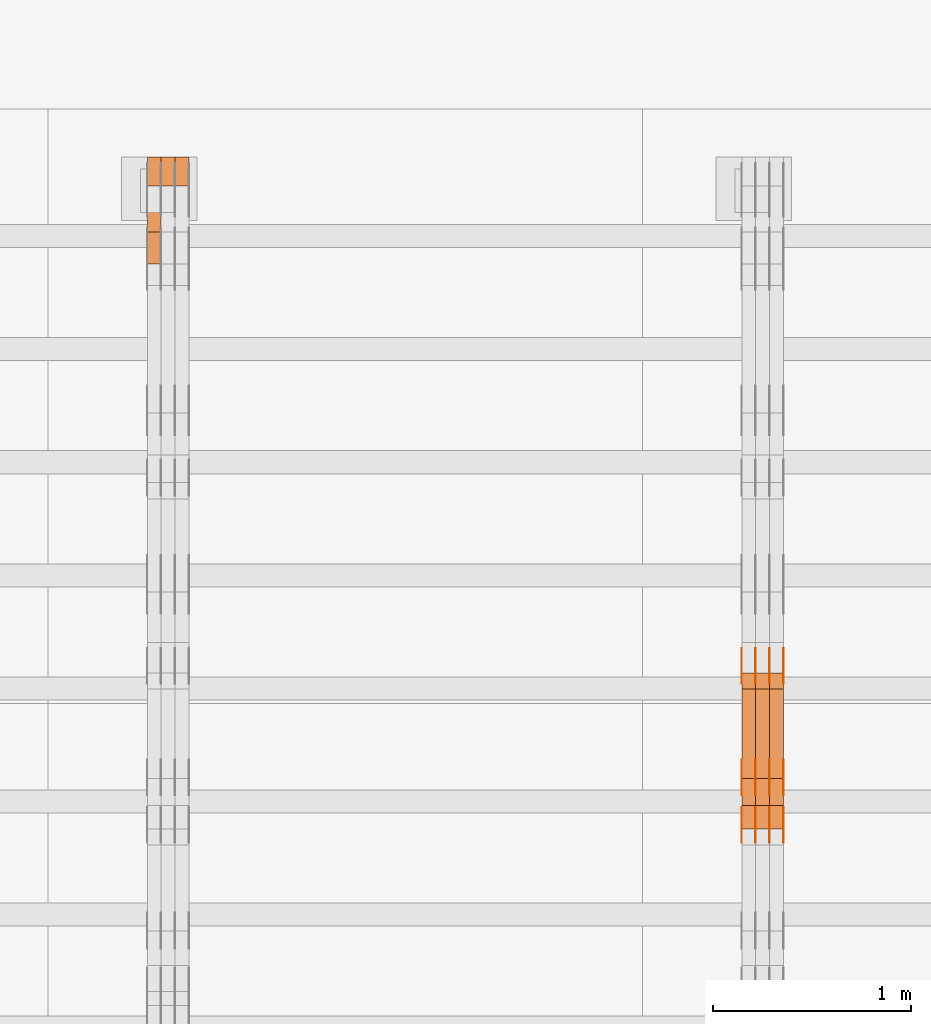
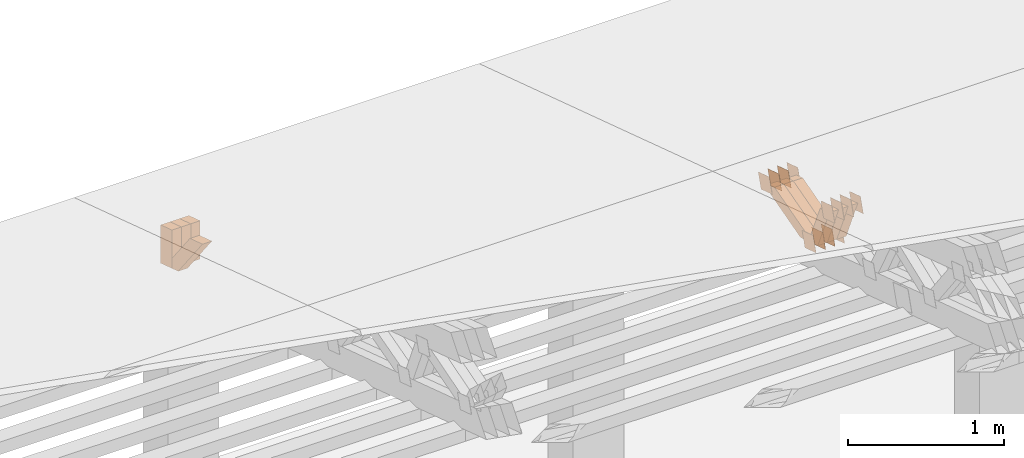
# One storey, part 361 of 385: 28 proxies.
"""IFC2X3 building model written with IfcOpenShell, lengths in millimetres."""

import ifcopenshell
import ifcopenshell.guid

model = None  # the IFC model being written
_history = None  # IfcOwnerHistory: only IFC2X3 demands one
_inside = {}  # id of a spatial element -> (the spatial element, [elements in it])
_under = {}  # id of a project, library or spatial element -> (it, [spatial elements below it])
_declared = {}  # id of a project -> (the project, [libraries it declares])
_typed = {}  # id of a type object -> (the type object, [elements of that type])
_made_of = {}  # id of a material, layer set ... -> (it, [elements and type objects made of it])


def new_model(schema):
    """Start an empty IFC model of exactly this schema.

    Asked for "IFC4X3", IfcOpenShell would pick the latest addendum, in which some entities
    have other attributes; the version numbers below select the first issue.
    IFC2X3 requires an IfcOwnerHistory on every rooted entity: one is made here for all.
    """
    global model, _history
    if schema == "IFC4X3":
        model = ifcopenshell.file(schema_version=(4, 3, 0, 0))
    else:
        model = ifcopenshell.file(schema=schema)
    _inside.clear()
    _under.clear()
    _declared.clear()
    _typed.clear()
    _made_of.clear()
    _history = None
    if model.schema == "IFC2X3":
        org = make("IfcOrganization", Name="unknown")
        user = make(
            "IfcPersonAndOrganization",
            ThePerson=make("IfcPerson", FamilyName="unknown"),
            TheOrganization=org,
        )
        app = make(
            "IfcApplication",
            ApplicationDeveloper=org,
            Version="unknown",
            ApplicationFullName="unknown",
            ApplicationIdentifier="unknown",
        )
        _history = make(
            "IfcOwnerHistory",
            OwningUser=user,
            OwningApplication=app,
            ChangeAction="ADDED",
            CreationDate=0,
        )
    return model


def make(cls, **values):
    """One entity of the class cls with the attributes given. An attribute that is None is left unset."""
    return model.create_entity(
        cls, **{name: value for name, value in values.items() if value is not None}
    )


def entity(cls, *values):
    """Any entity or typed value of the class cls, its attributes in the order of the schema. None: left unset."""
    e = model.create_entity(cls)
    for i, value in enumerate(values):
        if value is not None:
            e[i] = value
    return e


def rooted(cls, **values):
    """An entity with a GlobalId (a new one), such as an element, a storey or a relation."""
    return make(cls, GlobalId=ifcopenshell.guid.new(), OwnerHistory=_history, **values)


def si_unit(unit_type, name, prefix=None):
    """IfcSIUnit, for example si_unit("LENGTHUNIT", "METRE", prefix="MILLI")."""
    return make("IfcSIUnit", UnitType=unit_type, Prefix=prefix, Name=name)


def converted_unit(unit_type, name, factor, base, dimensions=None, offset=None):
    """IfcConversionBasedUnit, such as the inch: factor (a typed value) times the base unit."""
    return make(
        "IfcConversionBasedUnit"
        if offset is None
        else "IfcConversionBasedUnitWithOffset",
        ConversionOffset=offset,
        Dimensions=None
        if dimensions is None
        else entity("IfcDimensionalExponents", *dimensions),
        UnitType=unit_type,
        Name=name,
        ConversionFactor=make(
            "IfcMeasureWithUnit", ValueComponent=factor, UnitComponent=base
        ),
    )


def derived_unit(unit_type, elements):
    """IfcDerivedUnit: a product of units, each with its exponent."""
    return make(
        "IfcDerivedUnit",
        Elements=[
            make("IfcDerivedUnitElement", Unit=unit, Exponent=power)
            for unit, power in elements
        ],
        UnitType=unit_type,
    )


def assignment(units):
    """IfcUnitAssignment: the units of a project."""
    return None if units is None else make("IfcUnitAssignment", Units=units)


def point(xyz):
    """IfcCartesianPoint."""
    return None if xyz is None else make("IfcCartesianPoint", Coordinates=xyz)


def direction(xyz):
    """IfcDirection."""
    return None if xyz is None else make("IfcDirection", DirectionRatios=xyz)


def frame(location, z_axis=None, x_axis=None):
    """IfcAxis2Placement3D, a coordinate frame: its origin and axes. An axis left out is left unset."""
    return make(
        "IfcAxis2Placement3D",
        Location=point(location),
        Axis=direction(z_axis),
        RefDirection=direction(x_axis),
    )


def origin():
    """The frame at (0, 0, 0) with its axes left unset."""
    return frame((0.0, 0.0, 0.0))


def place(relative_to, where):
    """IfcLocalPlacement: puts the frame where relative to a parent placement (None: the world)."""
    return make(
        "IfcLocalPlacement", PlacementRelTo=relative_to, RelativePlacement=where
    )


def context(
    kind, dimensions, precision=None, world=None, true_north=None, identifier=None
):
    """IfcGeometricRepresentationContext, for example the 3D "Model" context."""
    return make(
        "IfcGeometricRepresentationContext",
        ContextIdentifier=identifier,
        ContextType=kind,
        CoordinateSpaceDimension=dimensions,
        Precision=precision,
        WorldCoordinateSystem=world,
        TrueNorth=true_north,
    )


def subcontext(parent, identifier, kind, view, scale=None):
    """IfcGeometricRepresentationSubContext, for example "Body" below "Model"."""
    return make(
        "IfcGeometricRepresentationSubContext",
        ContextIdentifier=identifier,
        ContextType=kind,
        ParentContext=parent,
        TargetScale=scale,
        TargetView=view,
    )


def project(units=None, contexts=None):
    """IfcProject with its units and contexts."""
    return rooted(
        "IfcProject",
        Name="project",
        RepresentationContexts=contexts,
        UnitsInContext=assignment(units),
    )


def spatial(cls, under=None, at=None, **own):
    """A site, building, storey or space (cls), placed at a placement, below another one or the project."""
    s = rooted(cls, ObjectPlacement=at, **own)
    if under is not None:
        _under.setdefault(under.id(), (under, []))[1].append(s)
    return s


def polyline(points):
    """IfcPolyline through the points."""
    return make("IfcPolyline", Points=[point(p) for p in points])


def outline(outer, holes=None, kind="AREA"):
    """IfcArbitraryClosedProfileDef: a profile drawn as a closed curve; with holes, ...WithVoids."""
    if holes is None:
        return make("IfcArbitraryClosedProfileDef", ProfileType=kind, OuterCurve=outer)
    return make(
        "IfcArbitraryProfileDefWithVoids",
        ProfileType=kind,
        OuterCurve=outer,
        InnerCurves=holes,
    )


def extrude(swept, where, along, depth):
    """IfcExtrudedAreaSolid: the profile swept, set in the frame where, extruded along a direction by depth."""
    return make(
        "IfcExtrudedAreaSolid",
        SweptArea=swept,
        Position=where,
        ExtrudedDirection=direction(along),
        Depth=depth,
    )


def shape(context_of_items, identifier, shape_type, items):
    """IfcShapeRepresentation: the items that make up one representation, for example the "Body"."""
    return make(
        "IfcShapeRepresentation",
        ContextOfItems=context_of_items,
        RepresentationIdentifier=identifier,
        RepresentationType=shape_type,
        Items=items,
    )


def source(mapping_origin, context_of_items, identifier, shape_type, items):
    """IfcRepresentationMap: a shape defined once, which mapped items show again and again."""
    return make(
        "IfcRepresentationMap",
        MappingOrigin=mapping_origin,
        MappedRepresentation=shape(context_of_items, identifier, shape_type, items),
    )


def transform(
    local_origin,
    x_axis=None,
    y_axis=None,
    z_axis=None,
    scale=None,
    scale2=None,
    scale3=None,
    uniform=True,
):
    """IfcCartesianTransformationOperator3D, or its non-uniform kind. x_axis, y_axis, z_axis: its Axis1, 2, 3."""
    if uniform:
        return make(
            "IfcCartesianTransformationOperator3D",
            Axis1=direction(x_axis),
            Axis2=direction(y_axis),
            LocalOrigin=point(local_origin),
            Scale=scale,
            Axis3=direction(z_axis),
        )
    return make(
        "IfcCartesianTransformationOperator3DnonUniform",
        Axis1=direction(x_axis),
        Axis2=direction(y_axis),
        LocalOrigin=point(local_origin),
        Scale=scale,
        Axis3=direction(z_axis),
        Scale2=scale2,
        Scale3=scale3,
    )


def mapped(mapping_source, mapping_target):
    """IfcMappedItem: shows the shape of a source again, moved by a transform."""
    return make(
        "IfcMappedItem", MappingSource=mapping_source, MappingTarget=mapping_target
    )


def material(Name=None, Category=None):
    """IfcMaterial."""
    return make("IfcMaterial", Name=Name, Category=Category)


def made_of(thing, what):
    """Note that an element or type object is made of a material, layer set ...; save() writes the relation."""
    if what is not None:
        _made_of.setdefault(what.id(), (what, []))[1].append(thing)
    return thing


def type_object(cls, material=None, **own):
    """A type object (cls), such as IfcWallType, which elements share."""
    return made_of(rooted(cls, **own), material)


def type_shapes(of_type, sources):
    """Give a type object the sources (RepresentationMaps) that its elements show as mapped items."""
    of_type.RepresentationMaps = sources


def element(
    cls,
    number,
    at=None,
    inside=None,
    cuts=None,
    type_object=None,
    material=None,
    context=None,
    identifier="Body",
    shape_type=None,
    held_by="IfcProductDefinitionShape",
    body=None,
    shapes=None,
    **own,
):
    """One element of the class cls, such as IfcWall. Its Tag is "e" and its number.

    at: its placement. inside: the storey or other place that contains it. cuts: it is an
    opening in that element (IfcRelVoidsElement). A single representation is given by context,
    identifier, shape_type and body (its items); several are given by shapes. held_by: the class
    of the entity that holds the representations. save() writes the other relations.
    """
    e = rooted(cls, Tag="e%d" % number, ObjectPlacement=at, **own)
    if body is not None:
        shapes = [shape(context, identifier, shape_type, body)]
    if shapes is not None:
        e.Representation = make(held_by, Representations=shapes)
    if inside is not None:
        _inside.setdefault(inside.id(), (inside, []))[1].append(e)
    if cuts is not None:
        rooted(
            "IfcRelVoidsElement", RelatingBuildingElement=cuts, RelatedOpeningElement=e
        )
    if type_object is not None:
        _typed.setdefault(type_object.id(), (type_object, []))[1].append(e)
    return made_of(e, material)


def aggregate(whole, parts):
    """IfcRelAggregates: a whole, such as a stair, and the parts it consists of."""
    return rooted("IfcRelAggregates", RelatingObject=whole, RelatedObjects=parts)


def save(model, path):
    """Write the relations noted so far, then the file.

    IfcRelAggregates (storeys below a building ...), IfcRelContainedInSpatialStructure (elements
    in a storey), IfcRelDefinesByType, IfcRelAssociatesMaterial and IfcRelDeclares: one each for
    every whole, place, type object, material and project.
    """
    for whole, parts in _under.values():
        aggregate(whole, parts)
    for where, things in _inside.values():
        rooted(
            "IfcRelContainedInSpatialStructure",
            RelatedElements=things,
            RelatingStructure=where,
        )
    for kind, things in _typed.values():
        rooted("IfcRelDefinesByType", RelatedObjects=things, RelatingType=kind)
    for what, things in _made_of.values():
        rooted("IfcRelAssociatesMaterial", RelatedObjects=things, RelatingMaterial=what)
    for by, libraries in _declared.values():
        rooted("IfcRelDeclares", RelatingContext=by, RelatedDefinitions=libraries)
    model.write(path)


model = new_model("IFC2X3")

# Units and contexts
model_context = context("Model", 3, precision=0.01, world=origin(), true_north=direction((6.12303176911189e-17, 1.0)))
body_context = subcontext(model_context, "Body", "Model", "MODEL_VIEW")
ifc_project = project(units=[si_unit("LENGTHUNIT", "METRE", prefix="MILLI"), si_unit("AREAUNIT", "SQUARE_METRE"), si_unit("VOLUMEUNIT", "CUBIC_METRE"), converted_unit("PLANEANGLEUNIT", "DEGREE", entity("IfcRatioMeasure", 0.0174532925199433), si_unit("PLANEANGLEUNIT", "RADIAN"), dimensions=[0, 0, 0, 0, 0, 0, 0]), si_unit("MASSUNIT", "GRAM", prefix="KILO"), derived_unit("MASSDENSITYUNIT", [(si_unit("MASSUNIT", "GRAM", prefix="KILO"), 1), (si_unit("LENGTHUNIT", "METRE"), -3)]), si_unit("TIMEUNIT", "SECOND"), si_unit("FREQUENCYUNIT", "HERTZ"), si_unit("THERMODYNAMICTEMPERATUREUNIT", "DEGREE_CELSIUS"), derived_unit("THERMALTRANSMITTANCEUNIT", [(si_unit("MASSUNIT", "GRAM", prefix="KILO"), 1), (si_unit("THERMODYNAMICTEMPERATUREUNIT", "KELVIN"), -1), (si_unit("TIMEUNIT", "SECOND"), -3)]), derived_unit("VOLUMETRICFLOWRATEUNIT", [(si_unit("LENGTHUNIT", "METRE"), 3), (si_unit("TIMEUNIT", "SECOND"), -1)]), si_unit("ELECTRICCURRENTUNIT", "AMPERE"), si_unit("ELECTRICVOLTAGEUNIT", "VOLT"), si_unit("POWERUNIT", "WATT"), si_unit("FORCEUNIT", "NEWTON", prefix="KILO"), si_unit("ILLUMINANCEUNIT", "LUX"), si_unit("LUMINOUSFLUXUNIT", "LUMEN"), si_unit("LUMINOUSINTENSITYUNIT", "CANDELA"), derived_unit("USERDEFINED", [(si_unit("MASSUNIT", "GRAM", prefix="KILO"), -1), (si_unit("LENGTHUNIT", "METRE"), -2), (si_unit("TIMEUNIT", "SECOND"), 3), (si_unit("LUMINOUSFLUXUNIT", "LUMEN"), 1)]), derived_unit("LINEARVELOCITYUNIT", [(si_unit("LENGTHUNIT", "METRE"), 1), (si_unit("TIMEUNIT", "SECOND"), -1)]), si_unit("PRESSUREUNIT", "PASCAL"), derived_unit("USERDEFINED", [(si_unit("LENGTHUNIT", "METRE"), -2), (si_unit("MASSUNIT", "GRAM", prefix="KILO"), 1), (si_unit("TIMEUNIT", "SECOND"), -2)])], contexts=[model_context])

# Site, building, storey
site_placement = place(None, origin())
site = spatial("IfcSite", under=ifc_project, at=site_placement, CompositionType="ELEMENT")
building_placement = place(site_placement, origin())
building = spatial("IfcBuilding", under=site, at=building_placement, CompositionType="ELEMENT")
storey_placement = place(building_placement, origin())
storey = spatial("IfcBuildingStorey", under=building, at=storey_placement, Name="Default", CompositionType="ELEMENT", Elevation=0.0)

# Proxies
ifc_material_1 = material(Name="IfcSurfaceStyle #540806")
building_element_proxy_type_1 = type_object("IfcBuildingElementProxyType", PredefinedType="NOTDEFINED", material=ifc_material_1)
shared_shape_1 = source(origin(), body_context, "Body", "SweptSolid", [
    extrude(outline(polyline([(-74.9998888504569, -59.9999264677525), (74.999884859074, -59.9999264677525), (74.9998699895559, 59.9999264677525), (-74.999865998173, 59.9999264677525), (-74.9998888504569, -59.9999264677525)])), frame((74.9999170714918, 60.0000016373507, 0.0), z_axis=(0.0, 0.0, 1.0), x_axis=(-1.0, 0.0, 0.0)), (0.0, 0.0, 1.0), 1.3),
])
type_shapes(building_element_proxy_type_1, [shared_shape_1])
proxy_1_placement = place(building_placement, frame((45386.3, 23182.5962361838, 1409.76695322432), z_axis=(-1.0, 0.0, 0.0), x_axis=(0.0, -0.951056516295154, 0.309016994374948)))
element("IfcBuildingElementProxy", 1, at=proxy_1_placement, inside=storey, type_object=building_element_proxy_type_1, material=ifc_material_1, context=body_context, shape_type="MappedRepresentation", body=[
    mapped(shared_shape_1, transform((0.0, 0.0, 0.0), scale=1.0)),
])
ifc_material_2 = material(Name="IfcSurfaceStyle #540749")
building_element_proxy_type_2 = type_object("IfcBuildingElementProxyType", PredefinedType="NOTDEFINED", material=ifc_material_2)
shared_shape_2 = source(origin(), body_context, "Body", "SweptSolid", [
    extrude(outline(polyline([(-74.9998888504569, -59.9999264677525), (74.999884859074, -59.9999264677525), (74.9998699895559, 59.9999264677525), (-74.999865998173, 59.9999264677525), (-74.9998888504569, -59.9999264677525)])), frame((74.9999170714918, 60.0000016373507, 0.0), z_axis=(0.0, 0.0, 1.0), x_axis=(-1.0, 0.0, 0.0)), (0.0, 0.0, 1.0), 1.3),
])
type_shapes(building_element_proxy_type_2, [shared_shape_2])
proxy_2_placement = place(building_placement, frame((45315.0, 23182.5962361838, 1409.76695322432), z_axis=(-1.0, 0.0, 0.0), x_axis=(0.0, -0.951056516295154, 0.309016994374948)))
element("IfcBuildingElementProxy", 2, at=proxy_2_placement, inside=storey, type_object=building_element_proxy_type_2, material=ifc_material_2, context=body_context, shape_type="MappedRepresentation", body=[
    mapped(shared_shape_2, transform((0.0, 0.0, 0.0), scale=1.0)),
])
ifc_material_3 = material(Name="IfcSurfaceStyle #540692")
building_element_proxy_type_3 = type_object("IfcBuildingElementProxyType", PredefinedType="NOTDEFINED", material=ifc_material_3)
shared_shape_3 = source(origin(), body_context, "Body", "SweptSolid", [
    extrude(outline(polyline([(-74.9998888504569, -59.9999264677525), (74.999884859074, -59.9999264677525), (74.9998699895559, 59.9999264677525), (-74.999865998173, 59.9999264677525), (-74.9998888504569, -59.9999264677525)])), frame((74.9999170714918, 60.0000016373507, 0.0), z_axis=(0.0, 0.0, 1.0), x_axis=(-1.0, 0.0, 0.0)), (0.0, 0.0, 1.0), 1.3),
])
type_shapes(building_element_proxy_type_3, [shared_shape_3])
proxy_3_placement = place(building_placement, frame((45316.3, 23182.5962361838, 1409.76695322432), z_axis=(-1.0, 0.0, 0.0), x_axis=(0.0, -0.951056516295154, 0.309016994374948)))
element("IfcBuildingElementProxy", 3, at=proxy_3_placement, inside=storey, type_object=building_element_proxy_type_3, material=ifc_material_3, context=body_context, shape_type="MappedRepresentation", body=[
    mapped(shared_shape_3, transform((0.0, 0.0, 0.0), scale=1.0)),
])
ifc_material_4 = material(Name="IfcSurfaceStyle #540635")
building_element_proxy_type_4 = type_object("IfcBuildingElementProxyType", PredefinedType="NOTDEFINED", material=ifc_material_4)
shared_shape_4 = source(origin(), body_context, "Body", "SweptSolid", [
    extrude(outline(polyline([(-74.9998888504569, -59.9999264677525), (74.999884859074, -59.9999264677525), (74.9998699895559, 59.9999264677525), (-74.999865998173, 59.9999264677525), (-74.9998888504569, -59.9999264677525)])), frame((74.9999170714918, 60.0000016373507, 0.0), z_axis=(0.0, 0.0, 1.0), x_axis=(-1.0, 0.0, 0.0)), (0.0, 0.0, 1.0), 1.29999999999999),
])
type_shapes(building_element_proxy_type_4, [shared_shape_4])
proxy_4_placement = place(building_placement, frame((45245.0, 23182.5962361838, 1409.76695322432), z_axis=(-1.0, 0.0, 0.0), x_axis=(0.0, -0.951056516295154, 0.309016994374948)))
element("IfcBuildingElementProxy", 4, at=proxy_4_placement, inside=storey, type_object=building_element_proxy_type_4, material=ifc_material_4, context=body_context, shape_type="MappedRepresentation", body=[
    mapped(shared_shape_4, transform((0.0, 0.0, 0.0), scale=1.0)),
])
ifc_material_5 = material(Name="IfcSurfaceStyle #540578")
building_element_proxy_type_5 = type_object("IfcBuildingElementProxyType", PredefinedType="NOTDEFINED", material=ifc_material_5)
shared_shape_5 = source(origin(), body_context, "Body", "SweptSolid", [
    extrude(outline(polyline([(-74.9998888504569, -59.9999264677525), (74.999884859074, -59.9999264677525), (74.9998699895559, 59.9999264677525), (-74.999865998173, 59.9999264677525), (-74.9998888504569, -59.9999264677525)])), frame((74.9999170714918, 60.0000016373507, 0.0), z_axis=(0.0, 0.0, 1.0), x_axis=(-1.0, 0.0, 0.0)), (0.0, 0.0, 1.0), 1.29999999999999),
])
type_shapes(building_element_proxy_type_5, [shared_shape_5])
proxy_5_placement = place(building_placement, frame((45246.3, 23182.5962361838, 1409.76695322432), z_axis=(-1.0, 0.0, 0.0), x_axis=(0.0, -0.951056516295154, 0.309016994374948)))
element("IfcBuildingElementProxy", 5, at=proxy_5_placement, inside=storey, type_object=building_element_proxy_type_5, material=ifc_material_5, context=body_context, shape_type="MappedRepresentation", body=[
    mapped(shared_shape_5, transform((0.0, 0.0, 0.0), scale=1.0)),
])
ifc_material_6 = material(Name="IfcSurfaceStyle #540521")
building_element_proxy_type_6 = type_object("IfcBuildingElementProxyType", PredefinedType="NOTDEFINED", material=ifc_material_6)
shared_shape_6 = source(origin(), body_context, "Body", "SweptSolid", [
    extrude(outline(polyline([(-74.9998888504569, -59.9999264677525), (74.999884859074, -59.9999264677525), (74.9998699895559, 59.9999264677525), (-74.999865998173, 59.9999264677525), (-74.9998888504569, -59.9999264677525)])), frame((74.9999170714918, 60.0000016373507, 0.0), z_axis=(0.0, 0.0, 1.0), x_axis=(-1.0, 0.0, 0.0)), (0.0, 0.0, 1.0), 1.29999999999999),
])
type_shapes(building_element_proxy_type_6, [shared_shape_6])
proxy_6_placement = place(building_placement, frame((45175.0, 23182.5962361838, 1409.76695322432), z_axis=(-1.0, 0.0, 0.0), x_axis=(0.0, -0.951056516295154, 0.309016994374948)))
element("IfcBuildingElementProxy", 6, at=proxy_6_placement, inside=storey, type_object=building_element_proxy_type_6, material=ifc_material_6, context=body_context, shape_type="MappedRepresentation", body=[
    mapped(shared_shape_6, transform((0.0, 0.0, 0.0), scale=1.0)),
])
ifc_material_7 = material(Name="IfcSurfaceStyle #540464")
building_element_proxy_type_7 = type_object("IfcBuildingElementProxyType", PredefinedType="NOTDEFINED", material=ifc_material_7)
shared_shape_7 = source(origin(), body_context, "Body", "SweptSolid", [
    extrude(outline(polyline([(-75.000111611545, -60.0000599592451), (75.0000887592491, -60.0000599592451), (75.000111611545, 60.0000599592451), (-75.0000887592492, 60.0000599592451), (-75.000111611545, -60.0000599592451)])), frame((75.000111611545, 60.0000599592451, 0.0), z_axis=(0.0, 0.0, 1.0), x_axis=(-1.0, 0.0, 0.0)), (0.0, 0.0, 1.0), 1.3),
])
type_shapes(building_element_proxy_type_7, [shared_shape_7])
proxy_7_placement = place(building_placement, frame((45386.3, 23422.738257852, 1031.33757447264), z_axis=(-1.0, 0.0, 0.0), x_axis=(0.0, -0.951056516295124, 0.309016994375039)))
element("IfcBuildingElementProxy", 7, at=proxy_7_placement, inside=storey, type_object=building_element_proxy_type_7, material=ifc_material_7, context=body_context, shape_type="MappedRepresentation", body=[
    mapped(shared_shape_7, transform((0.0, 0.0, 0.0), scale=1.0)),
])
ifc_material_8 = material(Name="IfcSurfaceStyle #540407")
building_element_proxy_type_8 = type_object("IfcBuildingElementProxyType", PredefinedType="NOTDEFINED", material=ifc_material_8)
shared_shape_8 = source(origin(), body_context, "Body", "SweptSolid", [
    extrude(outline(polyline([(-75.000111611545, -60.0000599592451), (75.0000887592491, -60.0000599592451), (75.000111611545, 60.0000599592451), (-75.0000887592492, 60.0000599592451), (-75.000111611545, -60.0000599592451)])), frame((75.000111611545, 60.0000599592451, 0.0), z_axis=(0.0, 0.0, 1.0), x_axis=(-1.0, 0.0, 0.0)), (0.0, 0.0, 1.0), 1.3),
])
type_shapes(building_element_proxy_type_8, [shared_shape_8])
proxy_8_placement = place(building_placement, frame((45315.0, 23422.738257852, 1031.33757447264), z_axis=(-1.0, 0.0, 0.0), x_axis=(0.0, -0.951056516295124, 0.309016994375039)))
element("IfcBuildingElementProxy", 8, at=proxy_8_placement, inside=storey, type_object=building_element_proxy_type_8, material=ifc_material_8, context=body_context, shape_type="MappedRepresentation", body=[
    mapped(shared_shape_8, transform((0.0, 0.0, 0.0), scale=1.0)),
])
ifc_material_9 = material(Name="IfcSurfaceStyle #540350")
building_element_proxy_type_9 = type_object("IfcBuildingElementProxyType", PredefinedType="NOTDEFINED", material=ifc_material_9)
shared_shape_9 = source(origin(), body_context, "Body", "SweptSolid", [
    extrude(outline(polyline([(-75.000111611545, -60.0000599592451), (75.0000887592491, -60.0000599592451), (75.000111611545, 60.0000599592451), (-75.0000887592492, 60.0000599592451), (-75.000111611545, -60.0000599592451)])), frame((75.000111611545, 60.0000599592451, 0.0), z_axis=(0.0, 0.0, 1.0), x_axis=(-1.0, 0.0, 0.0)), (0.0, 0.0, 1.0), 1.3),
])
type_shapes(building_element_proxy_type_9, [shared_shape_9])
proxy_9_placement = place(building_placement, frame((45316.3, 23422.738257852, 1031.33757447264), z_axis=(-1.0, 0.0, 0.0), x_axis=(0.0, -0.951056516295124, 0.309016994375039)))
element("IfcBuildingElementProxy", 9, at=proxy_9_placement, inside=storey, type_object=building_element_proxy_type_9, material=ifc_material_9, context=body_context, shape_type="MappedRepresentation", body=[
    mapped(shared_shape_9, transform((0.0, 0.0, 0.0), scale=1.0)),
])
ifc_material_10 = material(Name="IfcSurfaceStyle #540293")
building_element_proxy_type_10 = type_object("IfcBuildingElementProxyType", PredefinedType="NOTDEFINED", material=ifc_material_10)
shared_shape_10 = source(origin(), body_context, "Body", "SweptSolid", [
    extrude(outline(polyline([(-75.000111611545, -60.0000599592451), (75.0000887592491, -60.0000599592451), (75.000111611545, 60.0000599592451), (-75.0000887592492, 60.0000599592451), (-75.000111611545, -60.0000599592451)])), frame((75.000111611545, 60.0000599592451, 0.0), z_axis=(0.0, 0.0, 1.0), x_axis=(-1.0, 0.0, 0.0)), (0.0, 0.0, 1.0), 1.29999999999999),
])
type_shapes(building_element_proxy_type_10, [shared_shape_10])
proxy_10_placement = place(building_placement, frame((45245.0, 23422.738257852, 1031.33757447264), z_axis=(-1.0, 0.0, 0.0), x_axis=(0.0, -0.951056516295124, 0.309016994375039)))
element("IfcBuildingElementProxy", 10, at=proxy_10_placement, inside=storey, type_object=building_element_proxy_type_10, material=ifc_material_10, context=body_context, shape_type="MappedRepresentation", body=[
    mapped(shared_shape_10, transform((0.0, 0.0, 0.0), scale=1.0)),
])
ifc_material_11 = material(Name="IfcSurfaceStyle #540236")
building_element_proxy_type_11 = type_object("IfcBuildingElementProxyType", PredefinedType="NOTDEFINED", material=ifc_material_11)
shared_shape_11 = source(origin(), body_context, "Body", "SweptSolid", [
    extrude(outline(polyline([(-75.000111611545, -60.0000599592451), (75.0000887592491, -60.0000599592451), (75.000111611545, 60.0000599592451), (-75.0000887592492, 60.0000599592451), (-75.000111611545, -60.0000599592451)])), frame((75.000111611545, 60.0000599592451, 0.0), z_axis=(0.0, 0.0, 1.0), x_axis=(-1.0, 0.0, 0.0)), (0.0, 0.0, 1.0), 1.29999999999999),
])
type_shapes(building_element_proxy_type_11, [shared_shape_11])
proxy_11_placement = place(building_placement, frame((45246.3, 23422.738257852, 1031.33757447264), z_axis=(-1.0, 0.0, 0.0), x_axis=(0.0, -0.951056516295124, 0.309016994375039)))
element("IfcBuildingElementProxy", 11, at=proxy_11_placement, inside=storey, type_object=building_element_proxy_type_11, material=ifc_material_11, context=body_context, shape_type="MappedRepresentation", body=[
    mapped(shared_shape_11, transform((0.0, 0.0, 0.0), scale=1.0)),
])
ifc_material_12 = material(Name="IfcSurfaceStyle #540179")
building_element_proxy_type_12 = type_object("IfcBuildingElementProxyType", PredefinedType="NOTDEFINED", material=ifc_material_12)
shared_shape_12 = source(origin(), body_context, "Body", "SweptSolid", [
    extrude(outline(polyline([(-75.000111611545, -60.0000599592451), (75.0000887592491, -60.0000599592451), (75.000111611545, 60.0000599592451), (-75.0000887592492, 60.0000599592451), (-75.000111611545, -60.0000599592451)])), frame((75.000111611545, 60.0000599592451, 0.0), z_axis=(0.0, 0.0, 1.0), x_axis=(-1.0, 0.0, 0.0)), (0.0, 0.0, 1.0), 1.29999999999999),
])
type_shapes(building_element_proxy_type_12, [shared_shape_12])
proxy_12_placement = place(building_placement, frame((45175.0, 23422.738257852, 1031.33757447264), z_axis=(-1.0, 0.0, 0.0), x_axis=(0.0, -0.951056516295124, 0.309016994375039)))
element("IfcBuildingElementProxy", 12, at=proxy_12_placement, inside=storey, type_object=building_element_proxy_type_12, material=ifc_material_12, context=body_context, shape_type="MappedRepresentation", body=[
    mapped(shared_shape_12, transform((0.0, 0.0, 0.0), scale=1.0)),
])
ifc_material_13 = material(Name="IfcSurfaceStyle #539780")
building_element_proxy_type_13 = type_object("IfcBuildingElementProxyType", PredefinedType="NOTDEFINED", material=ifc_material_13)
shared_shape_13 = source(origin(), body_context, "Body", "SweptSolid", [
    extrude(outline(polyline([(-74.9999766548731, -60.0000019113547), (75.000223715922, -60.0000019113547), (74.9997444633404, 60.0000019113548), (-74.9999915243893, 60.0000019113547), (-74.9999766548731, -60.0000019113547)])), frame((75.0002237159219, 60.0000770809529, 0.0), z_axis=(0.0, 0.0, 1.0), x_axis=(-1.0, 0.0, 0.0)), (0.0, 0.0, 1.0), 1.3),
])
type_shapes(building_element_proxy_type_13, [shared_shape_13])
proxy_13_placement = place(building_placement, frame((45386.3, 23985.88473314, 1148.76266928562), z_axis=(-1.0, 0.0, 0.0), x_axis=(0.0, -0.951056516295154, 0.309016994374948)))
element("IfcBuildingElementProxy", 13, at=proxy_13_placement, inside=storey, type_object=building_element_proxy_type_13, material=ifc_material_13, context=body_context, shape_type="MappedRepresentation", body=[
    mapped(shared_shape_13, transform((0.0, 0.0, 0.0), scale=1.0)),
])
ifc_material_14 = material(Name="IfcSurfaceStyle #539723")
building_element_proxy_type_14 = type_object("IfcBuildingElementProxyType", PredefinedType="NOTDEFINED", material=ifc_material_14)
shared_shape_14 = source(origin(), body_context, "Body", "SweptSolid", [
    extrude(outline(polyline([(-74.9999766548731, -60.0000019113547), (75.000223715922, -60.0000019113547), (74.9997444633404, 60.0000019113548), (-74.9999915243893, 60.0000019113547), (-74.9999766548731, -60.0000019113547)])), frame((75.0002237159219, 60.0000770809529, 0.0), z_axis=(0.0, 0.0, 1.0), x_axis=(-1.0, 0.0, 0.0)), (0.0, 0.0, 1.0), 1.3),
])
type_shapes(building_element_proxy_type_14, [shared_shape_14])
proxy_14_placement = place(building_placement, frame((45315.0, 23985.88473314, 1148.76266928562), z_axis=(-1.0, 0.0, 0.0), x_axis=(0.0, -0.951056516295154, 0.309016994374948)))
element("IfcBuildingElementProxy", 14, at=proxy_14_placement, inside=storey, type_object=building_element_proxy_type_14, material=ifc_material_14, context=body_context, shape_type="MappedRepresentation", body=[
    mapped(shared_shape_14, transform((0.0, 0.0, 0.0), scale=1.0)),
])
ifc_material_15 = material(Name="IfcSurfaceStyle #539666")
building_element_proxy_type_15 = type_object("IfcBuildingElementProxyType", PredefinedType="NOTDEFINED", material=ifc_material_15)
shared_shape_15 = source(origin(), body_context, "Body", "SweptSolid", [
    extrude(outline(polyline([(-74.9999766548731, -60.0000019113547), (75.000223715922, -60.0000019113547), (74.9997444633404, 60.0000019113548), (-74.9999915243893, 60.0000019113547), (-74.9999766548731, -60.0000019113547)])), frame((75.0002237159219, 60.0000770809529, 0.0), z_axis=(0.0, 0.0, 1.0), x_axis=(-1.0, 0.0, 0.0)), (0.0, 0.0, 1.0), 1.3),
])
type_shapes(building_element_proxy_type_15, [shared_shape_15])
proxy_15_placement = place(building_placement, frame((45316.3, 23985.88473314, 1148.76266928562), z_axis=(-1.0, 0.0, 0.0), x_axis=(0.0, -0.951056516295154, 0.309016994374948)))
element("IfcBuildingElementProxy", 15, at=proxy_15_placement, inside=storey, type_object=building_element_proxy_type_15, material=ifc_material_15, context=body_context, shape_type="MappedRepresentation", body=[
    mapped(shared_shape_15, transform((0.0, 0.0, 0.0), scale=1.0)),
])
ifc_material_16 = material(Name="IfcSurfaceStyle #539609")
building_element_proxy_type_16 = type_object("IfcBuildingElementProxyType", PredefinedType="NOTDEFINED", material=ifc_material_16)
shared_shape_16 = source(origin(), body_context, "Body", "SweptSolid", [
    extrude(outline(polyline([(-74.9999766548731, -60.0000019113547), (75.000223715922, -60.0000019113547), (74.9997444633404, 60.0000019113548), (-74.9999915243893, 60.0000019113547), (-74.9999766548731, -60.0000019113547)])), frame((75.0002237159219, 60.0000770809529, 0.0), z_axis=(0.0, 0.0, 1.0), x_axis=(-1.0, 0.0, 0.0)), (0.0, 0.0, 1.0), 1.29999999999999),
])
type_shapes(building_element_proxy_type_16, [shared_shape_16])
proxy_16_placement = place(building_placement, frame((45245.0, 23985.88473314, 1148.76266928562), z_axis=(-1.0, 0.0, 0.0), x_axis=(0.0, -0.951056516295154, 0.309016994374948)))
element("IfcBuildingElementProxy", 16, at=proxy_16_placement, inside=storey, type_object=building_element_proxy_type_16, material=ifc_material_16, context=body_context, shape_type="MappedRepresentation", body=[
    mapped(shared_shape_16, transform((0.0, 0.0, 0.0), scale=1.0)),
])
ifc_material_17 = material(Name="IfcSurfaceStyle #539552")
building_element_proxy_type_17 = type_object("IfcBuildingElementProxyType", PredefinedType="NOTDEFINED", material=ifc_material_17)
shared_shape_17 = source(origin(), body_context, "Body", "SweptSolid", [
    extrude(outline(polyline([(-74.9999766548731, -60.0000019113547), (75.000223715922, -60.0000019113547), (74.9997444633404, 60.0000019113548), (-74.9999915243893, 60.0000019113547), (-74.9999766548731, -60.0000019113547)])), frame((75.0002237159219, 60.0000770809529, 0.0), z_axis=(0.0, 0.0, 1.0), x_axis=(-1.0, 0.0, 0.0)), (0.0, 0.0, 1.0), 1.29999999999999),
])
type_shapes(building_element_proxy_type_17, [shared_shape_17])
proxy_17_placement = place(building_placement, frame((45246.3, 23985.88473314, 1148.76266928562), z_axis=(-1.0, 0.0, 0.0), x_axis=(0.0, -0.951056516295154, 0.309016994374948)))
element("IfcBuildingElementProxy", 17, at=proxy_17_placement, inside=storey, type_object=building_element_proxy_type_17, material=ifc_material_17, context=body_context, shape_type="MappedRepresentation", body=[
    mapped(shared_shape_17, transform((0.0, 0.0, 0.0), scale=1.0)),
])
ifc_material_18 = material(Name="IfcSurfaceStyle #539495")
building_element_proxy_type_18 = type_object("IfcBuildingElementProxyType", PredefinedType="NOTDEFINED", material=ifc_material_18)
shared_shape_18 = source(origin(), body_context, "Body", "SweptSolid", [
    extrude(outline(polyline([(-74.9999766548731, -60.0000019113547), (75.000223715922, -60.0000019113547), (74.9997444633404, 60.0000019113548), (-74.9999915243893, 60.0000019113547), (-74.9999766548731, -60.0000019113547)])), frame((75.0002237159219, 60.0000770809529, 0.0), z_axis=(0.0, 0.0, 1.0), x_axis=(-1.0, 0.0, 0.0)), (0.0, 0.0, 1.0), 1.29999999999999),
])
type_shapes(building_element_proxy_type_18, [shared_shape_18])
proxy_18_placement = place(building_placement, frame((45175.0, 23985.88473314, 1148.76266928562), z_axis=(-1.0, 0.0, 0.0), x_axis=(0.0, -0.951056516295154, 0.309016994374948)))
element("IfcBuildingElementProxy", 18, at=proxy_18_placement, inside=storey, type_object=building_element_proxy_type_18, material=ifc_material_18, context=body_context, shape_type="MappedRepresentation", body=[
    mapped(shared_shape_18, transform((0.0, 0.0, 0.0), scale=1.0)),
])
ifc_material_19 = material(Name="IfcSurfaceStyle #527954")
building_element_proxy_type_19 = type_object("IfcBuildingElementProxyType", Name="T1-W48 527952", PredefinedType="NOTDEFINED", material=ifc_material_19)
shared_shape_19 = source(origin(), body_context, "Body", "SweptSolid", [
    extrude(outline(polyline([(-179.014659681673, -47.5001725722734), (164.970934255612, -47.5001725722734), (158.689466064455, -0.000154807462590734), (117.249257288395, 47.5002499760047), (-261.894997926789, 47.5002499760047), (-179.014659681673, -47.5001725722734)])), frame((164.970934255612, 47.5002499760047, 0.0), z_axis=(0.0, 0.0, 1.0), x_axis=(-1.0, 0.0, 0.0)), (0.0, 0.0, 1.0), 70.0),
])
type_shapes(building_element_proxy_type_19, [shared_shape_19])
proxy_19_placement = place(building_placement, frame((45385.0, 23276.999081075, 1103.96808602322), z_axis=(-1.0, 0.0, 0.0), x_axis=(0.0, -0.392372359952232, 0.919806463961586)))
element("IfcBuildingElementProxy", 19, at=proxy_19_placement, inside=storey, type_object=building_element_proxy_type_19, material=ifc_material_19, Name="T1-W48", context=body_context, shape_type="MappedRepresentation", body=[
    mapped(shared_shape_19, transform((0.0, 0.0, 0.0), scale=1.0)),
])
ifc_material_20 = material(Name="IfcSurfaceStyle #527888")
building_element_proxy_type_20 = type_object("IfcBuildingElementProxyType", Name="T1-W48 527886", PredefinedType="NOTDEFINED", material=ifc_material_20)
shared_shape_20 = source(origin(), body_context, "Body", "SweptSolid", [
    extrude(outline(polyline([(-179.014659681673, -47.5001725722734), (164.970934255612, -47.5001725722734), (158.689466064455, -0.000154807462590734), (117.249257288395, 47.5002499760047), (-261.894997926789, 47.5002499760047), (-179.014659681673, -47.5001725722734)])), frame((164.970934255612, 47.5002499760047, 0.0), z_axis=(0.0, 0.0, 1.0), x_axis=(-1.0, 0.0, 0.0)), (0.0, 0.0, 1.0), 70.0),
])
type_shapes(building_element_proxy_type_20, [shared_shape_20])
proxy_20_placement = place(building_placement, frame((45315.0, 23276.999081075, 1103.96808602322), z_axis=(-1.0, 0.0, 0.0), x_axis=(0.0, -0.392372359952232, 0.919806463961586)))
element("IfcBuildingElementProxy", 20, at=proxy_20_placement, inside=storey, type_object=building_element_proxy_type_20, material=ifc_material_20, Name="T1-W48", context=body_context, shape_type="MappedRepresentation", body=[
    mapped(shared_shape_20, transform((0.0, 0.0, 0.0), scale=1.0)),
])
ifc_material_21 = material(Name="IfcSurfaceStyle #527822")
building_element_proxy_type_21 = type_object("IfcBuildingElementProxyType", Name="T1-W48 527820", PredefinedType="NOTDEFINED", material=ifc_material_21)
shared_shape_21 = source(origin(), body_context, "Body", "SweptSolid", [
    extrude(outline(polyline([(-179.014659681673, -47.5001725722734), (164.970934255612, -47.5001725722734), (158.689466064455, -0.000154807462590734), (117.249257288395, 47.5002499760047), (-261.894997926789, 47.5002499760047), (-179.014659681673, -47.5001725722734)])), frame((164.970934255612, 47.5002499760047, 0.0), z_axis=(0.0, 0.0, 1.0), x_axis=(-1.0, 0.0, 0.0)), (0.0, 0.0, 1.0), 70.0),
])
type_shapes(building_element_proxy_type_21, [shared_shape_21])
proxy_21_placement = place(building_placement, frame((45245.0, 23276.999081075, 1103.96808602322), z_axis=(-1.0, 0.0, 0.0), x_axis=(0.0, -0.392372359952232, 0.919806463961586)))
element("IfcBuildingElementProxy", 21, at=proxy_21_placement, inside=storey, type_object=building_element_proxy_type_21, material=ifc_material_21, Name="T1-W48", context=body_context, shape_type="MappedRepresentation", body=[
    mapped(shared_shape_21, transform((0.0, 0.0, 0.0), scale=1.0)),
])
ifc_material_22 = material(Name="IfcSurfaceStyle #527558")
building_element_proxy_type_22 = type_object("IfcBuildingElementProxyType", Name="T1-W16 527556", PredefinedType="NOTDEFINED", material=ifc_material_22)
shared_shape_22 = source(origin(), body_context, "Body", "SweptSolid", [
    extrude(outline(polyline([(-370.757125176074, -47.4999438400901), (145.934648032773, -47.4999438400902), (217.511780472151, -4.11857860007858e-05), (234.91308660316, 47.4999644329832), (-227.602389932009, 47.4999644329832), (-370.757125176074, -47.4999438400901)])), frame((234.913162148205, 47.5000075544853, 0.0), z_axis=(0.0, 0.0, 1.0), x_axis=(-1.0, 0.0, 0.0)), (0.0, 0.0, 1.0), 70.0),
])
type_shapes(building_element_proxy_type_22, [shared_shape_22])
proxy_22_placement = place(building_placement, frame((45385.0, 23927.1704945031, 1199.43003244777), z_axis=(-1.0, 0.0, 0.0), x_axis=(0.0, -0.963308155550006, -0.268397834288666)))
element("IfcBuildingElementProxy", 22, at=proxy_22_placement, inside=storey, type_object=building_element_proxy_type_22, material=ifc_material_22, Name="T1-W16", context=body_context, shape_type="MappedRepresentation", body=[
    mapped(shared_shape_22, transform((0.0, 0.0, 0.0), scale=1.0)),
])
ifc_material_23 = material(Name="IfcSurfaceStyle #527492")
building_element_proxy_type_23 = type_object("IfcBuildingElementProxyType", Name="T1-W16 527490", PredefinedType="NOTDEFINED", material=ifc_material_23)
shared_shape_23 = source(origin(), body_context, "Body", "SweptSolid", [
    extrude(outline(polyline([(-370.757125176074, -47.4999438400901), (145.934648032773, -47.4999438400902), (217.511780472151, -4.11857860007858e-05), (234.91308660316, 47.4999644329832), (-227.602389932009, 47.4999644329832), (-370.757125176074, -47.4999438400901)])), frame((234.913162148205, 47.5000075544853, 0.0), z_axis=(0.0, 0.0, 1.0), x_axis=(-1.0, 0.0, 0.0)), (0.0, 0.0, 1.0), 70.0),
])
type_shapes(building_element_proxy_type_23, [shared_shape_23])
proxy_23_placement = place(building_placement, frame((45315.0, 23927.1704945031, 1199.43003244777), z_axis=(-1.0, 0.0, 0.0), x_axis=(0.0, -0.963308155550006, -0.268397834288666)))
element("IfcBuildingElementProxy", 23, at=proxy_23_placement, inside=storey, type_object=building_element_proxy_type_23, material=ifc_material_23, Name="T1-W16", context=body_context, shape_type="MappedRepresentation", body=[
    mapped(shared_shape_23, transform((0.0, 0.0, 0.0), scale=1.0)),
])
ifc_material_24 = material(Name="IfcSurfaceStyle #527426")
building_element_proxy_type_24 = type_object("IfcBuildingElementProxyType", Name="T1-W16 527424", PredefinedType="NOTDEFINED", material=ifc_material_24)
shared_shape_24 = source(origin(), body_context, "Body", "SweptSolid", [
    extrude(outline(polyline([(-370.757125176074, -47.4999438400901), (145.934648032773, -47.4999438400902), (217.511780472151, -4.11857860007858e-05), (234.91308660316, 47.4999644329832), (-227.602389932009, 47.4999644329832), (-370.757125176074, -47.4999438400901)])), frame((234.913162148205, 47.5000075544853, 0.0), z_axis=(0.0, 0.0, 1.0), x_axis=(-1.0, 0.0, 0.0)), (0.0, 0.0, 1.0), 70.0),
])
type_shapes(building_element_proxy_type_24, [shared_shape_24])
proxy_24_placement = place(building_placement, frame((45245.0, 23927.1704945031, 1199.43003244777), z_axis=(-1.0, 0.0, 0.0), x_axis=(0.0, -0.963308155550006, -0.268397834288666)))
element("IfcBuildingElementProxy", 24, at=proxy_24_placement, inside=storey, type_object=building_element_proxy_type_24, material=ifc_material_24, Name="T1-W16", context=body_context, shape_type="MappedRepresentation", body=[
    mapped(shared_shape_24, transform((0.0, 0.0, 0.0), scale=1.0)),
])
ifc_material_25 = material(Name="IfcSurfaceStyle #491014")
building_element_proxy_type_25 = type_object("IfcBuildingElementProxyType", Name="T1-W21 491012", PredefinedType="NOTDEFINED", material=ifc_material_25)
shared_shape_25 = source(origin(), body_context, "Body", "SweptSolid", [
    extrude(outline(polyline([(-209.199362597501, -47.5000308982766), (168.813164734153, -47.5000308982766), (229.900717355638, -2.18385470334148e-05), (159.828709317766, 47.5000418175501), (-349.343228810055, 47.5000418175502), (-209.199362597501, -47.5000308982766)])), frame((229.900720156071, 47.5000418175501, 0.0), z_axis=(0.0, 0.0, 1.0), x_axis=(-1.0, 0.0, 0.0)), (0.0, 0.0, 1.0), 70.0),
])
type_shapes(building_element_proxy_type_25, [shared_shape_25])
proxy_25_placement = place(building_placement, frame((42245.0, 26317.5019908272, 112.518372832984), z_axis=(-1.0, 0.0, 0.0), x_axis=(0.0, -0.613839629272042, 0.789430750310097)))
element("IfcBuildingElementProxy", 25, at=proxy_25_placement, inside=storey, type_object=building_element_proxy_type_25, material=ifc_material_25, Name="T1-W21", context=body_context, shape_type="MappedRepresentation", body=[
    mapped(shared_shape_25, transform((0.0, 0.0, 0.0), scale=1.0)),
])
ifc_material_26 = material(Name="IfcSurfaceStyle #490579")
building_element_proxy_type_26 = type_object("IfcBuildingElementProxyType", Name="T1-E2 490577", PredefinedType="NOTDEFINED", material=ifc_material_26)
shared_shape_26 = source(origin(), body_context, "Body", "SweptSolid", [
    extrude(outline(polyline([(-126.644535064697, -72.4999999999998), (173.757884979248, -72.4999999999998), (126.644542694092, 72.4999999999998), (-173.757892608642, 72.4999999999998), (-126.644535064697, -72.4999999999998)])), frame((173.757890653796, 72.5000000000002, 0.0), z_axis=(0.0, 0.0, 1.0), x_axis=(-1.0, 0.0, 0.0)), (0.0, 0.0, 1.0), 70.0),
])
type_shapes(building_element_proxy_type_26, [shared_shape_26])
proxy_26_placement = place(building_placement, frame((42385.0, 26500.0, 442.078222227283), z_axis=(-1.0, 0.0, 0.0), x_axis=(0.0, 0.0, -1.0)))
element("IfcBuildingElementProxy", 26, at=proxy_26_placement, inside=storey, type_object=building_element_proxy_type_26, material=ifc_material_26, Name="T1-E2", context=body_context, shape_type="MappedRepresentation", body=[
    mapped(shared_shape_26, transform((0.0, 0.0, 0.0), scale=1.0)),
])
ifc_material_27 = material(Name="IfcSurfaceStyle #490522")
building_element_proxy_type_27 = type_object("IfcBuildingElementProxyType", Name="T1-E2 490520", PredefinedType="NOTDEFINED", material=ifc_material_27)
shared_shape_27 = source(origin(), body_context, "Body", "SweptSolid", [
    extrude(outline(polyline([(-126.644535064697, -72.4999999999998), (173.757884979248, -72.4999999999998), (126.644542694092, 72.4999999999998), (-173.757892608642, 72.4999999999998), (-126.644535064697, -72.4999999999998)])), frame((173.757890653796, 72.5000000000002, 0.0), z_axis=(0.0, 0.0, 1.0), x_axis=(-1.0, 0.0, 0.0)), (0.0, 0.0, 1.0), 70.0),
])
type_shapes(building_element_proxy_type_27, [shared_shape_27])
proxy_27_placement = place(building_placement, frame((42315.0, 26500.0, 442.078222227283), z_axis=(-1.0, 0.0, 0.0), x_axis=(0.0, 0.0, -1.0)))
element("IfcBuildingElementProxy", 27, at=proxy_27_placement, inside=storey, type_object=building_element_proxy_type_27, material=ifc_material_27, Name="T1-E2", context=body_context, shape_type="MappedRepresentation", body=[
    mapped(shared_shape_27, transform((0.0, 0.0, 0.0), scale=1.0)),
])
ifc_material_28 = material(Name="IfcSurfaceStyle #490465")
building_element_proxy_type_28 = type_object("IfcBuildingElementProxyType", Name="T1-E2 490463", PredefinedType="NOTDEFINED", material=ifc_material_28)
shared_shape_28 = source(origin(), body_context, "Body", "SweptSolid", [
    extrude(outline(polyline([(-126.644535064697, -72.4999999999998), (173.757884979248, -72.4999999999998), (126.644542694092, 72.4999999999998), (-173.757892608642, 72.4999999999998), (-126.644535064697, -72.4999999999998)])), frame((173.757890653796, 72.5000000000002, 0.0), z_axis=(0.0, 0.0, 1.0), x_axis=(-1.0, 0.0, 0.0)), (0.0, 0.0, 1.0), 70.0),
])
type_shapes(building_element_proxy_type_28, [shared_shape_28])
proxy_28_placement = place(building_placement, frame((42245.0, 26500.0, 442.078222227283), z_axis=(-1.0, 0.0, 0.0), x_axis=(0.0, 0.0, -1.0)))
element("IfcBuildingElementProxy", 28, at=proxy_28_placement, inside=storey, type_object=building_element_proxy_type_28, material=ifc_material_28, Name="T1-E2", context=body_context, shape_type="MappedRepresentation", body=[
    mapped(shared_shape_28, transform((0.0, 0.0, 0.0), scale=1.0)),
])

save(model, "model.ifc")
